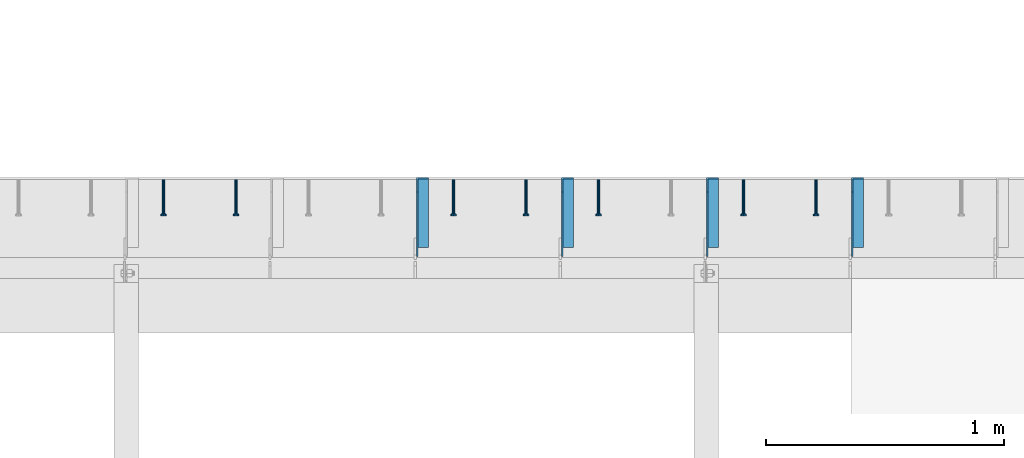
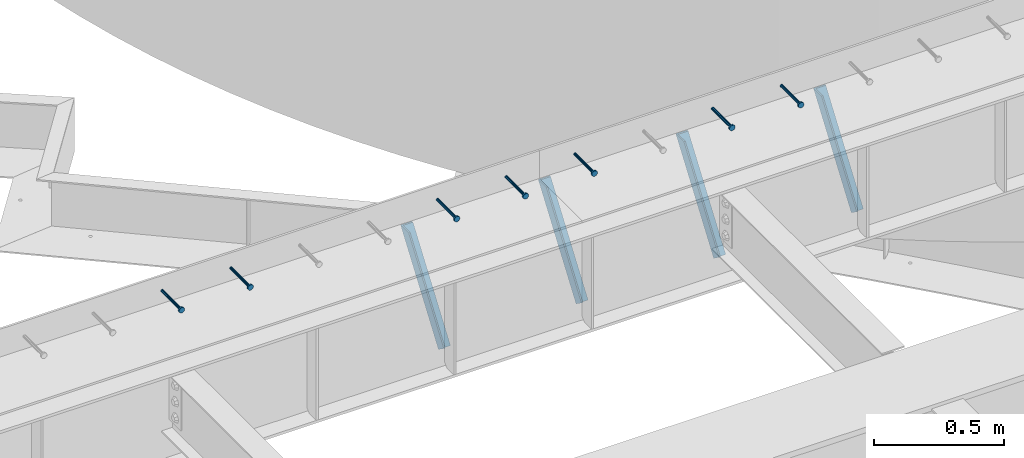
# One storey, part 1351 of 1763: 7 beams, 4 members, 8 elements without a shape of their own.
"""IFC2X3 building model written with IfcOpenShell, lengths in millimetres."""

from ifc_helpers import new_model, si_unit, frame, origin_with_axes, place, context, subcontext, project, spatial, faceted_brep, material, type_object, element, aggregate, save


model = new_model("IFC2X3")

# Units and contexts
model_context = context("Model", 3, precision=1e-05, world=origin_with_axes())
body_context = subcontext(model_context, "Body", "Model", "MODEL_VIEW")
ifc_project = project(units=[si_unit("LENGTHUNIT", "METRE", prefix="MILLI"), si_unit("AREAUNIT", "SQUARE_METRE"), si_unit("VOLUMEUNIT", "CUBIC_METRE"), si_unit("MASSUNIT", "GRAM", prefix="KILO"), si_unit("TIMEUNIT", "SECOND"), si_unit("PLANEANGLEUNIT", "RADIAN"), si_unit("SOLIDANGLEUNIT", "STERADIAN"), si_unit("THERMODYNAMICTEMPERATUREUNIT", "DEGREE_CELSIUS"), si_unit("LUMINOUSINTENSITYUNIT", "LUMEN")], contexts=[model_context])

# Site, building, storey
site_placement = place(None, origin_with_axes())
site = spatial("IfcSite", under=ifc_project, at=site_placement, CompositionType="ELEMENT")
building_placement = place(site_placement, origin_with_axes())
building = spatial("IfcBuilding", under=site, at=building_placement, Name="Undefined", CompositionType="ELEMENT")
storey_placement = place(building_placement, origin_with_axes())
storey = spatial("IfcBuildingStorey", under=building, at=storey_placement, Name="Undefined", CompositionType="ELEMENT", Elevation=0.0)

# Assembly, beam
assembly_1_placement = place(storey_placement, origin_with_axes())
assembly_1 = element("IfcElementAssembly", 1, at=assembly_1_placement, inside=storey, Name="HEADED STUD ANCHOR", AssemblyPlace="NOTDEFINED", PredefinedType="RIGID_FRAME")
ifc_material_1 = material(Name="STEEL/A108")
beam_type = type_object("IfcBeamType", PredefinedType="NOTDEFINED")
beam_1_placement = place(assembly_1_placement, frame((-51378.8747736983, 53984.5250183106, 5264.23140606069), z_axis=(0.0, 0.0, 1.0), x_axis=(0.0, -1.0, 0.0)))
beam_1 = element("IfcBeam", 2, at=beam_1_placement, type_object=beam_type, material=ifc_material_1, Name="HEADED STUD ANCHOR", context=body_context, shape_type="Brep", body=[
    faceted_brep([(0.0, -3.1800000667572, 5.5), (0.0, -5.5, 3.1800000667572), (141.732000000002, -5.5, 3.1800000667572), (141.732000000002, -3.1800000667572, 5.5), (0.0, -6.34999999999491, 1.45519152283669e-11), (141.732000000002, -6.34999990463257, 0.0), (0.0, -5.5, -3.1800000667572), (141.732000000002, -5.5, -3.1800000667572), (0.0, -3.1800000667572, -5.5), (141.732000000002, -3.1800000667572, -5.5), (0.0, 0.0, -6.34999990463257), (141.732000000002, 0.0, -6.34999990463257), (0.0, 3.1800000667572, -5.5), (141.732000000002, 3.1800000667572, -5.5), (0.0, 5.5, -3.1800000667572), (141.732000000002, 5.5, -3.1800000667572), (0.0, 6.34999999999491, -2.91038304567337e-11), (141.732000000002, 6.34999990463257, 0.0), (0.0, 5.5, 3.1800000667572), (141.732000000002, 5.5, 3.1800000667572), (0.0, 3.1800000667572, 5.5), (141.732000000002, 3.1800000667572, 5.5), (0.0, 0.0, 6.34999990463257), (141.732000000002, 0.0, 6.34999990463257), (144.780000000001, -10.9899997711182, 6.34999990463257), (144.780000000001, -6.34000015258789, 10.9899997711182), (144.780000000001, -12.6999998092651, 0.0), (144.780000000001, -10.9899997711182, -6.34999990463257), (144.780000000001, -6.34000015258789, -10.9899997711182), (144.780000000001, 0.0, -12.6899995803833), (144.780000000001, 6.34000015258789, -10.9899997711182), (144.780000000001, 10.9899997711182, -6.34999990463257), (144.780000000001, 12.6999998092651, 0.0), (144.780000000001, 10.9899997711182, 6.34999990463257), (144.780000000001, 6.34000015258789, 10.9899997711182), (144.780000000001, 0.0, 12.6899995803833), (152.400000000001, -10.9899997711182, 6.34999990463257), (152.400000000001, -6.34000015258789, 10.9899997711182), (152.400000000001, -12.6999998092651, 0.0), (152.400000000001, -10.9899997711182, -6.34999990463257), (152.400000000001, -6.34000015258789, -10.9899997711182), (152.400000000001, 0.0, -12.6899995803833), (152.400000000001, 6.34000015258789, -10.9899997711182), (152.400000000001, 10.9899997711182, -6.34999990463257), (152.400000000001, 12.6999998092651, 0.0), (152.400000000001, 10.9899997711182, 6.34999990463257), (152.400000000001, 6.34000015258789, 10.9899997711182), (152.400000000001, 0.0, 12.6899995803833)], [[[0, 1, 2, 3]], [[1, 4, 5, 2]], [[4, 6, 7, 5]], [[6, 8, 9, 7]], [[8, 10, 11, 9]], [[10, 12, 13, 11]], [[12, 14, 15, 13]], [[14, 16, 17, 15]], [[16, 18, 19, 17]], [[18, 20, 21, 19]], [[20, 22, 23, 21]], [[22, 0, 3, 23]], [[22, 20, 18, 16, 14, 12, 10, 8, 6, 4, 1, 0]], [[3, 2, 24, 25]], [[2, 5, 26, 24]], [[5, 7, 27, 26]], [[7, 9, 28, 27]], [[9, 11, 29, 28]], [[11, 13, 30, 29]], [[13, 15, 31, 30]], [[15, 17, 32, 31]], [[17, 19, 33, 32]], [[19, 21, 34, 33]], [[21, 23, 35, 34]], [[23, 3, 25, 35]], [[25, 24, 36, 37]], [[24, 26, 38, 36]], [[26, 27, 39, 38]], [[27, 28, 40, 39]], [[28, 29, 41, 40]], [[29, 30, 42, 41]], [[30, 31, 43, 42]], [[31, 32, 44, 43]], [[32, 33, 45, 44]], [[33, 34, 46, 45]], [[34, 35, 47, 46]], [[35, 25, 37, 47]], [[38, 39, 40, 41, 42, 43, 44, 45, 46, 47, 37, 36]]]),
])
aggregate(assembly_1, [beam_1])

assembly_2_placement = place(storey_placement, origin_with_axes())
assembly_2 = element("IfcElementAssembly", 3, at=assembly_2_placement, inside=storey, Name="HEADED STUD ANCHOR", AssemblyPlace="NOTDEFINED", PredefinedType="RIGID_FRAME")
beam_2_placement = place(assembly_2_placement, frame((-51683.6747736983, 53984.5250183106, 5264.23140606069), z_axis=(0.0, 0.0, 1.0), x_axis=(0.0, -1.0, 0.0)))
beam_2 = element("IfcBeam", 4, at=beam_2_placement, type_object=beam_type, material=ifc_material_1, Name="HEADED STUD ANCHOR", context=body_context, shape_type="Brep", body=[
    faceted_brep([(0.0, -3.1800000667572, 5.5), (0.0, -5.5, 3.1800000667572), (141.732000000002, -5.5, 3.1800000667572), (141.732000000002, -3.1800000667572, 5.5), (0.0, -6.34999999999491, 1.45519152283669e-11), (141.732000000002, -6.34999990463257, 0.0), (0.0, -5.5, -3.1800000667572), (141.732000000002, -5.5, -3.1800000667572), (0.0, -3.1800000667572, -5.5), (141.732000000002, -3.1800000667572, -5.5), (0.0, 0.0, -6.34999990463257), (141.732000000002, 0.0, -6.34999990463257), (0.0, 3.1800000667572, -5.5), (141.732000000002, 3.1800000667572, -5.5), (0.0, 5.5, -3.1800000667572), (141.732000000002, 5.5, -3.1800000667572), (0.0, 6.34999999999491, -2.91038304567337e-11), (141.732000000002, 6.34999990463257, 0.0), (0.0, 5.5, 3.1800000667572), (141.732000000002, 5.5, 3.1800000667572), (0.0, 3.1800000667572, 5.5), (141.732000000002, 3.1800000667572, 5.5), (0.0, 0.0, 6.34999990463257), (141.732000000002, 0.0, 6.34999990463257), (144.780000000001, -10.9899997711182, 6.34999990463257), (144.780000000001, -6.34000015258789, 10.9899997711182), (144.780000000001, -12.6999998092651, 0.0), (144.780000000001, -10.9899997711182, -6.34999990463257), (144.780000000001, -6.34000015258789, -10.9899997711182), (144.780000000001, 0.0, -12.6899995803833), (144.780000000001, 6.34000015258789, -10.9899997711182), (144.780000000001, 10.9899997711182, -6.34999990463257), (144.780000000001, 12.6999998092651, 0.0), (144.780000000001, 10.9899997711182, 6.34999990463257), (144.780000000001, 6.34000015258789, 10.9899997711182), (144.780000000001, 0.0, 12.6899995803833), (152.400000000001, -10.9899997711182, 6.34999990463257), (152.400000000001, -6.34000015258789, 10.9899997711182), (152.400000000001, -12.6999998092651, 0.0), (152.400000000001, -10.9899997711182, -6.34999990463257), (152.400000000001, -6.34000015258789, -10.9899997711182), (152.400000000001, 0.0, -12.6899995803833), (152.400000000001, 6.34000015258789, -10.9899997711182), (152.400000000001, 10.9899997711182, -6.34999990463257), (152.400000000001, 12.6999998092651, 0.0), (152.400000000001, 10.9899997711182, 6.34999990463257), (152.400000000001, 6.34000015258789, 10.9899997711182), (152.400000000001, 0.0, 12.6899995803833)], [[[0, 1, 2, 3]], [[1, 4, 5, 2]], [[4, 6, 7, 5]], [[6, 8, 9, 7]], [[8, 10, 11, 9]], [[10, 12, 13, 11]], [[12, 14, 15, 13]], [[14, 16, 17, 15]], [[16, 18, 19, 17]], [[18, 20, 21, 19]], [[20, 22, 23, 21]], [[22, 0, 3, 23]], [[22, 20, 18, 16, 14, 12, 10, 8, 6, 4, 1, 0]], [[3, 2, 24, 25]], [[2, 5, 26, 24]], [[5, 7, 27, 26]], [[7, 9, 28, 27]], [[9, 11, 29, 28]], [[11, 13, 30, 29]], [[13, 15, 31, 30]], [[15, 17, 32, 31]], [[17, 19, 33, 32]], [[19, 21, 34, 33]], [[21, 23, 35, 34]], [[23, 3, 25, 35]], [[25, 24, 36, 37]], [[24, 26, 38, 36]], [[26, 27, 39, 38]], [[27, 28, 40, 39]], [[28, 29, 41, 40]], [[29, 30, 42, 41]], [[30, 31, 43, 42]], [[31, 32, 44, 43]], [[32, 33, 45, 44]], [[33, 34, 46, 45]], [[34, 35, 47, 46]], [[35, 25, 37, 47]], [[38, 39, 40, 41, 42, 43, 44, 45, 46, 47, 37, 36]]]),
])
aggregate(assembly_2, [beam_2])

assembly_3_placement = place(storey_placement, origin_with_axes())
assembly_3 = element("IfcElementAssembly", 5, at=assembly_3_placement, inside=storey, Name="HEADED STUD ANCHOR", AssemblyPlace="NOTDEFINED", PredefinedType="RIGID_FRAME")
beam_3_placement = place(assembly_3_placement, frame((-52293.2747736983, 53984.5250183106, 5264.23140606069), z_axis=(0.0, 0.0, 1.0), x_axis=(0.0, -1.0, 0.0)))
beam_3 = element("IfcBeam", 6, at=beam_3_placement, type_object=beam_type, material=ifc_material_1, Name="HEADED STUD ANCHOR", context=body_context, shape_type="Brep", body=[
    faceted_brep([(0.0, -3.1800000667572, 5.5), (0.0, -5.5, 3.1800000667572), (141.732000000002, -5.5, 3.1800000667572), (141.732000000002, -3.1800000667572, 5.5), (0.0, -6.34999999999491, 1.45519152283669e-11), (141.732000000002, -6.34999990463257, 0.0), (0.0, -5.5, -3.1800000667572), (141.732000000002, -5.5, -3.1800000667572), (0.0, -3.1800000667572, -5.5), (141.732000000002, -3.1800000667572, -5.5), (0.0, 0.0, -6.34999990463257), (141.732000000002, 0.0, -6.34999990463257), (0.0, 3.1800000667572, -5.5), (141.732000000002, 3.1800000667572, -5.5), (0.0, 5.5, -3.1800000667572), (141.732000000002, 5.5, -3.1800000667572), (0.0, 6.34999999999491, -2.91038304567337e-11), (141.732000000002, 6.34999990463257, 0.0), (0.0, 5.5, 3.1800000667572), (141.732000000002, 5.5, 3.1800000667572), (0.0, 3.1800000667572, 5.5), (141.732000000002, 3.1800000667572, 5.5), (0.0, 0.0, 6.34999990463257), (141.732000000002, 0.0, 6.34999990463257), (144.780000000001, -10.9899997711182, 6.34999990463257), (144.780000000001, -6.34000015258789, 10.9899997711182), (144.780000000001, -12.6999998092651, 0.0), (144.780000000001, -10.9899997711182, -6.34999990463257), (144.780000000001, -6.34000015258789, -10.9899997711182), (144.780000000001, 0.0, -12.6899995803833), (144.780000000001, 6.34000015258789, -10.9899997711182), (144.780000000001, 10.9899997711182, -6.34999990463257), (144.780000000001, 12.6999998092651, 0.0), (144.780000000001, 10.9899997711182, 6.34999990463257), (144.780000000001, 6.34000015258789, 10.9899997711182), (144.780000000001, 0.0, 12.6899995803833), (152.400000000001, -10.9899997711182, 6.34999990463257), (152.400000000001, -6.34000015258789, 10.9899997711182), (152.400000000001, -12.6999998092651, 0.0), (152.400000000001, -10.9899997711182, -6.34999990463257), (152.400000000001, -6.34000015258789, -10.9899997711182), (152.400000000001, 0.0, -12.6899995803833), (152.400000000001, 6.34000015258789, -10.9899997711182), (152.400000000001, 10.9899997711182, -6.34999990463257), (152.400000000001, 12.6999998092651, 0.0), (152.400000000001, 10.9899997711182, 6.34999990463257), (152.400000000001, 6.34000015258789, 10.9899997711182), (152.400000000001, 0.0, 12.6899995803833)], [[[0, 1, 2, 3]], [[1, 4, 5, 2]], [[4, 6, 7, 5]], [[6, 8, 9, 7]], [[8, 10, 11, 9]], [[10, 12, 13, 11]], [[12, 14, 15, 13]], [[14, 16, 17, 15]], [[16, 18, 19, 17]], [[18, 20, 21, 19]], [[20, 22, 23, 21]], [[22, 0, 3, 23]], [[22, 20, 18, 16, 14, 12, 10, 8, 6, 4, 1, 0]], [[3, 2, 24, 25]], [[2, 5, 26, 24]], [[5, 7, 27, 26]], [[7, 9, 28, 27]], [[9, 11, 29, 28]], [[11, 13, 30, 29]], [[13, 15, 31, 30]], [[15, 17, 32, 31]], [[17, 19, 33, 32]], [[19, 21, 34, 33]], [[21, 23, 35, 34]], [[23, 3, 25, 35]], [[25, 24, 36, 37]], [[24, 26, 38, 36]], [[26, 27, 39, 38]], [[27, 28, 40, 39]], [[28, 29, 41, 40]], [[29, 30, 42, 41]], [[30, 31, 43, 42]], [[31, 32, 44, 43]], [[32, 33, 45, 44]], [[33, 34, 46, 45]], [[34, 35, 47, 46]], [[35, 25, 37, 47]], [[38, 39, 40, 41, 42, 43, 44, 45, 46, 47, 37, 36]]]),
])
aggregate(assembly_3, [beam_3])

assembly_4_placement = place(storey_placement, origin_with_axes())
assembly_4 = element("IfcElementAssembly", 7, at=assembly_4_placement, inside=storey, Name="HEADED STUD ANCHOR", AssemblyPlace="NOTDEFINED", PredefinedType="RIGID_FRAME")
beam_4_placement = place(assembly_4_placement, frame((-52598.0747736983, 53984.5250183106, 5264.23140606069), z_axis=(0.0, 0.0, 1.0), x_axis=(0.0, -1.0, 0.0)))
beam_4 = element("IfcBeam", 8, at=beam_4_placement, type_object=beam_type, material=ifc_material_1, Name="HEADED STUD ANCHOR", context=body_context, shape_type="Brep", body=[
    faceted_brep([(0.0, -3.1800000667572, 5.5), (0.0, -5.5, 3.1800000667572), (141.732000000002, -5.5, 3.1800000667572), (141.732000000002, -3.1800000667572, 5.5), (0.0, -6.34999999999491, 1.45519152283669e-11), (141.732000000002, -6.34999990463257, 0.0), (0.0, -5.5, -3.1800000667572), (141.732000000002, -5.5, -3.1800000667572), (0.0, -3.1800000667572, -5.5), (141.732000000002, -3.1800000667572, -5.5), (0.0, 0.0, -6.34999990463257), (141.732000000002, 0.0, -6.34999990463257), (0.0, 3.1800000667572, -5.5), (141.732000000002, 3.1800000667572, -5.5), (0.0, 5.5, -3.1800000667572), (141.732000000002, 5.5, -3.1800000667572), (0.0, 6.34999999999491, -2.91038304567337e-11), (141.732000000002, 6.34999990463257, 0.0), (0.0, 5.5, 3.1800000667572), (141.732000000002, 5.5, 3.1800000667572), (0.0, 3.1800000667572, 5.5), (141.732000000002, 3.1800000667572, 5.5), (0.0, 0.0, 6.34999990463257), (141.732000000002, 0.0, 6.34999990463257), (144.780000000001, -10.9899997711182, 6.34999990463257), (144.780000000001, -6.34000015258789, 10.9899997711182), (144.780000000001, -12.6999998092651, 0.0), (144.780000000001, -10.9899997711182, -6.34999990463257), (144.780000000001, -6.34000015258789, -10.9899997711182), (144.780000000001, 0.0, -12.6899995803833), (144.780000000001, 6.34000015258789, -10.9899997711182), (144.780000000001, 10.9899997711182, -6.34999990463257), (144.780000000001, 12.6999998092651, 0.0), (144.780000000001, 10.9899997711182, 6.34999990463257), (144.780000000001, 6.34000015258789, 10.9899997711182), (144.780000000001, 0.0, 12.6899995803833), (152.400000000001, -10.9899997711182, 6.34999990463257), (152.400000000001, -6.34000015258789, 10.9899997711182), (152.400000000001, -12.6999998092651, 0.0), (152.400000000001, -10.9899997711182, -6.34999990463257), (152.400000000001, -6.34000015258789, -10.9899997711182), (152.400000000001, 0.0, -12.6899995803833), (152.400000000001, 6.34000015258789, -10.9899997711182), (152.400000000001, 10.9899997711182, -6.34999990463257), (152.400000000001, 12.6999998092651, 0.0), (152.400000000001, 10.9899997711182, 6.34999990463257), (152.400000000001, 6.34000015258789, 10.9899997711182), (152.400000000001, 0.0, 12.6899995803833)], [[[0, 1, 2, 3]], [[1, 4, 5, 2]], [[4, 6, 7, 5]], [[6, 8, 9, 7]], [[8, 10, 11, 9]], [[10, 12, 13, 11]], [[12, 14, 15, 13]], [[14, 16, 17, 15]], [[16, 18, 19, 17]], [[18, 20, 21, 19]], [[20, 22, 23, 21]], [[22, 0, 3, 23]], [[22, 20, 18, 16, 14, 12, 10, 8, 6, 4, 1, 0]], [[3, 2, 24, 25]], [[2, 5, 26, 24]], [[5, 7, 27, 26]], [[7, 9, 28, 27]], [[9, 11, 29, 28]], [[11, 13, 30, 29]], [[13, 15, 31, 30]], [[15, 17, 32, 31]], [[17, 19, 33, 32]], [[19, 21, 34, 33]], [[21, 23, 35, 34]], [[23, 3, 25, 35]], [[25, 24, 36, 37]], [[24, 26, 38, 36]], [[26, 27, 39, 38]], [[27, 28, 40, 39]], [[28, 29, 41, 40]], [[29, 30, 42, 41]], [[30, 31, 43, 42]], [[31, 32, 44, 43]], [[32, 33, 45, 44]], [[33, 34, 46, 45]], [[34, 35, 47, 46]], [[35, 25, 37, 47]], [[38, 39, 40, 41, 42, 43, 44, 45, 46, 47, 37, 36]]]),
])
aggregate(assembly_4, [beam_4])

assembly_5_placement = place(storey_placement, origin_with_axes())
assembly_5 = element("IfcElementAssembly", 9, at=assembly_5_placement, inside=storey, Name="HEADED STUD ANCHOR", AssemblyPlace="NOTDEFINED", PredefinedType="RIGID_FRAME")
beam_5_placement = place(assembly_5_placement, frame((-52902.8747736983, 53984.5250183106, 5264.23140606069), z_axis=(0.0, 0.0, 1.0), x_axis=(0.0, -1.0, 0.0)))
beam_5 = element("IfcBeam", 10, at=beam_5_placement, type_object=beam_type, material=ifc_material_1, Name="HEADED STUD ANCHOR", context=body_context, shape_type="Brep", body=[
    faceted_brep([(0.0, -3.1800000667572, 5.5), (0.0, -5.5, 3.1800000667572), (141.732000000002, -5.5, 3.1800000667572), (141.732000000002, -3.1800000667572, 5.5), (0.0, -6.34999999999491, 1.45519152283669e-11), (141.732000000002, -6.34999990463257, 0.0), (0.0, -5.5, -3.1800000667572), (141.732000000002, -5.5, -3.1800000667572), (0.0, -3.1800000667572, -5.5), (141.732000000002, -3.1800000667572, -5.5), (0.0, 0.0, -6.34999990463257), (141.732000000002, 0.0, -6.34999990463257), (0.0, 3.1800000667572, -5.5), (141.732000000002, 3.1800000667572, -5.5), (0.0, 5.5, -3.1800000667572), (141.732000000002, 5.5, -3.1800000667572), (0.0, 6.34999999999491, -2.91038304567337e-11), (141.732000000002, 6.34999990463257, 0.0), (0.0, 5.5, 3.1800000667572), (141.732000000002, 5.5, 3.1800000667572), (0.0, 3.1800000667572, 5.5), (141.732000000002, 3.1800000667572, 5.5), (0.0, 0.0, 6.34999990463257), (141.732000000002, 0.0, 6.34999990463257), (144.780000000001, -10.9899997711182, 6.34999990463257), (144.780000000001, -6.34000015258789, 10.9899997711182), (144.780000000001, -12.6999998092651, 0.0), (144.780000000001, -10.9899997711182, -6.34999990463257), (144.780000000001, -6.34000015258789, -10.9899997711182), (144.780000000001, 0.0, -12.6899995803833), (144.780000000001, 6.34000015258789, -10.9899997711182), (144.780000000001, 10.9899997711182, -6.34999990463257), (144.780000000001, 12.6999998092651, 0.0), (144.780000000001, 10.9899997711182, 6.34999990463257), (144.780000000001, 6.34000015258789, 10.9899997711182), (144.780000000001, 0.0, 12.6899995803833), (152.400000000001, -10.9899997711182, 6.34999990463257), (152.400000000001, -6.34000015258789, 10.9899997711182), (152.400000000001, -12.6999998092651, 0.0), (152.400000000001, -10.9899997711182, -6.34999990463257), (152.400000000001, -6.34000015258789, -10.9899997711182), (152.400000000001, 0.0, -12.6899995803833), (152.400000000001, 6.34000015258789, -10.9899997711182), (152.400000000001, 10.9899997711182, -6.34999990463257), (152.400000000001, 12.6999998092651, 0.0), (152.400000000001, 10.9899997711182, 6.34999990463257), (152.400000000001, 6.34000015258789, 10.9899997711182), (152.400000000001, 0.0, 12.6899995803833)], [[[0, 1, 2, 3]], [[1, 4, 5, 2]], [[4, 6, 7, 5]], [[6, 8, 9, 7]], [[8, 10, 11, 9]], [[10, 12, 13, 11]], [[12, 14, 15, 13]], [[14, 16, 17, 15]], [[16, 18, 19, 17]], [[18, 20, 21, 19]], [[20, 22, 23, 21]], [[22, 0, 3, 23]], [[22, 20, 18, 16, 14, 12, 10, 8, 6, 4, 1, 0]], [[3, 2, 24, 25]], [[2, 5, 26, 24]], [[5, 7, 27, 26]], [[7, 9, 28, 27]], [[9, 11, 29, 28]], [[11, 13, 30, 29]], [[13, 15, 31, 30]], [[15, 17, 32, 31]], [[17, 19, 33, 32]], [[19, 21, 34, 33]], [[21, 23, 35, 34]], [[23, 3, 25, 35]], [[25, 24, 36, 37]], [[24, 26, 38, 36]], [[26, 27, 39, 38]], [[27, 28, 40, 39]], [[28, 29, 41, 40]], [[29, 30, 42, 41]], [[30, 31, 43, 42]], [[31, 32, 44, 43]], [[32, 33, 45, 44]], [[33, 34, 46, 45]], [[34, 35, 47, 46]], [[35, 25, 37, 47]], [[38, 39, 40, 41, 42, 43, 44, 45, 46, 47, 37, 36]]]),
])
aggregate(assembly_5, [beam_5])

assembly_6_placement = place(storey_placement, origin_with_axes())
assembly_6 = element("IfcElementAssembly", 11, at=assembly_6_placement, inside=storey, Name="HEADED STUD ANCHOR", AssemblyPlace="NOTDEFINED", PredefinedType="RIGID_FRAME")
beam_6_placement = place(assembly_6_placement, frame((-53817.2747736983, 53984.5250183106, 5264.23140606069), z_axis=(0.0, 0.0, 1.0), x_axis=(0.0, -1.0, 0.0)))
beam_6 = element("IfcBeam", 12, at=beam_6_placement, type_object=beam_type, material=ifc_material_1, Name="HEADED STUD ANCHOR", context=body_context, shape_type="Brep", body=[
    faceted_brep([(0.0, -3.1800000667572, 5.5), (0.0, -5.5, 3.1800000667572), (141.732000000002, -5.5, 3.1800000667572), (141.732000000002, -3.1800000667572, 5.5), (0.0, -6.34999999999491, 1.45519152283669e-11), (141.732000000002, -6.34999990463257, 0.0), (0.0, -5.5, -3.1800000667572), (141.732000000002, -5.5, -3.1800000667572), (0.0, -3.1800000667572, -5.5), (141.732000000002, -3.1800000667572, -5.5), (0.0, 0.0, -6.34999990463257), (141.732000000002, 0.0, -6.34999990463257), (0.0, 3.1800000667572, -5.5), (141.732000000002, 3.1800000667572, -5.5), (0.0, 5.5, -3.1800000667572), (141.732000000002, 5.5, -3.1800000667572), (0.0, 6.34999999999491, -2.91038304567337e-11), (141.732000000002, 6.34999990463257, 0.0), (0.0, 5.5, 3.1800000667572), (141.732000000002, 5.5, 3.1800000667572), (0.0, 3.1800000667572, 5.5), (141.732000000002, 3.1800000667572, 5.5), (0.0, 0.0, 6.34999990463257), (141.732000000002, 0.0, 6.34999990463257), (144.780000000001, -10.9899997711182, 6.34999990463257), (144.780000000001, -6.34000015258789, 10.9899997711182), (144.780000000001, -12.6999998092651, 0.0), (144.780000000001, -10.9899997711182, -6.34999990463257), (144.780000000001, -6.34000015258789, -10.9899997711182), (144.780000000001, 0.0, -12.6899995803833), (144.780000000001, 6.34000015258789, -10.9899997711182), (144.780000000001, 10.9899997711182, -6.34999990463257), (144.780000000001, 12.6999998092651, 0.0), (144.780000000001, 10.9899997711182, 6.34999990463257), (144.780000000001, 6.34000015258789, 10.9899997711182), (144.780000000001, 0.0, 12.6899995803833), (152.400000000001, -10.9899997711182, 6.34999990463257), (152.400000000001, -6.34000015258789, 10.9899997711182), (152.400000000001, -12.6999998092651, 0.0), (152.400000000001, -10.9899997711182, -6.34999990463257), (152.400000000001, -6.34000015258789, -10.9899997711182), (152.400000000001, 0.0, -12.6899995803833), (152.400000000001, 6.34000015258789, -10.9899997711182), (152.400000000001, 10.9899997711182, -6.34999990463257), (152.400000000001, 12.6999998092651, 0.0), (152.400000000001, 10.9899997711182, 6.34999990463257), (152.400000000001, 6.34000015258789, 10.9899997711182), (152.400000000001, 0.0, 12.6899995803833)], [[[0, 1, 2, 3]], [[1, 4, 5, 2]], [[4, 6, 7, 5]], [[6, 8, 9, 7]], [[8, 10, 11, 9]], [[10, 12, 13, 11]], [[12, 14, 15, 13]], [[14, 16, 17, 15]], [[16, 18, 19, 17]], [[18, 20, 21, 19]], [[20, 22, 23, 21]], [[22, 0, 3, 23]], [[22, 20, 18, 16, 14, 12, 10, 8, 6, 4, 1, 0]], [[3, 2, 24, 25]], [[2, 5, 26, 24]], [[5, 7, 27, 26]], [[7, 9, 28, 27]], [[9, 11, 29, 28]], [[11, 13, 30, 29]], [[13, 15, 31, 30]], [[15, 17, 32, 31]], [[17, 19, 33, 32]], [[19, 21, 34, 33]], [[21, 23, 35, 34]], [[23, 3, 25, 35]], [[25, 24, 36, 37]], [[24, 26, 38, 36]], [[26, 27, 39, 38]], [[27, 28, 40, 39]], [[28, 29, 41, 40]], [[29, 30, 42, 41]], [[30, 31, 43, 42]], [[31, 32, 44, 43]], [[32, 33, 45, 44]], [[33, 34, 46, 45]], [[34, 35, 47, 46]], [[35, 25, 37, 47]], [[38, 39, 40, 41, 42, 43, 44, 45, 46, 47, 37, 36]]]),
])
aggregate(assembly_6, [beam_6])

assembly_7_placement = place(storey_placement, origin_with_axes())
assembly_7 = element("IfcElementAssembly", 13, at=assembly_7_placement, inside=storey, Name="HEADED STUD ANCHOR", AssemblyPlace="NOTDEFINED", PredefinedType="RIGID_FRAME")
beam_7_placement = place(assembly_7_placement, frame((-54122.0747736983, 53984.5250183106, 5264.23140606069), z_axis=(0.0, 0.0, 1.0), x_axis=(0.0, -1.0, 0.0)))
beam_7 = element("IfcBeam", 14, at=beam_7_placement, type_object=beam_type, material=ifc_material_1, Name="HEADED STUD ANCHOR", context=body_context, shape_type="Brep", body=[
    faceted_brep([(0.0, -3.1800000667572, 5.5), (0.0, -5.5, 3.1800000667572), (141.732000000002, -5.5, 3.1800000667572), (141.732000000002, -3.1800000667572, 5.5), (0.0, -6.34999999999491, 1.45519152283669e-11), (141.732000000002, -6.34999990463257, 0.0), (0.0, -5.5, -3.1800000667572), (141.732000000002, -5.5, -3.1800000667572), (0.0, -3.1800000667572, -5.5), (141.732000000002, -3.1800000667572, -5.5), (0.0, 0.0, -6.34999990463257), (141.732000000002, 0.0, -6.34999990463257), (0.0, 3.1800000667572, -5.5), (141.732000000002, 3.1800000667572, -5.5), (0.0, 5.5, -3.1800000667572), (141.732000000002, 5.5, -3.1800000667572), (0.0, 6.34999999999491, -2.91038304567337e-11), (141.732000000002, 6.34999990463257, 0.0), (0.0, 5.5, 3.1800000667572), (141.732000000002, 5.5, 3.1800000667572), (0.0, 3.1800000667572, 5.5), (141.732000000002, 3.1800000667572, 5.5), (0.0, 0.0, 6.34999990463257), (141.732000000002, 0.0, 6.34999990463257), (144.780000000001, -10.9899997711182, 6.34999990463257), (144.780000000001, -6.34000015258789, 10.9899997711182), (144.780000000001, -12.6999998092651, 0.0), (144.780000000001, -10.9899997711182, -6.34999990463257), (144.780000000001, -6.34000015258789, -10.9899997711182), (144.780000000001, 0.0, -12.6899995803833), (144.780000000001, 6.34000015258789, -10.9899997711182), (144.780000000001, 10.9899997711182, -6.34999990463257), (144.780000000001, 12.6999998092651, 0.0), (144.780000000001, 10.9899997711182, 6.34999990463257), (144.780000000001, 6.34000015258789, 10.9899997711182), (144.780000000001, 0.0, 12.6899995803833), (152.400000000001, -10.9899997711182, 6.34999990463257), (152.400000000001, -6.34000015258789, 10.9899997711182), (152.400000000001, -12.6999998092651, 0.0), (152.400000000001, -10.9899997711182, -6.34999990463257), (152.400000000001, -6.34000015258789, -10.9899997711182), (152.400000000001, 0.0, -12.6899995803833), (152.400000000001, 6.34000015258789, -10.9899997711182), (152.400000000001, 10.9899997711182, -6.34999990463257), (152.400000000001, 12.6999998092651, 0.0), (152.400000000001, 10.9899997711182, 6.34999990463257), (152.400000000001, 6.34000015258789, 10.9899997711182), (152.400000000001, 0.0, 12.6899995803833)], [[[0, 1, 2, 3]], [[1, 4, 5, 2]], [[4, 6, 7, 5]], [[6, 8, 9, 7]], [[8, 10, 11, 9]], [[10, 12, 13, 11]], [[12, 14, 15, 13]], [[14, 16, 17, 15]], [[16, 18, 19, 17]], [[18, 20, 21, 19]], [[20, 22, 23, 21]], [[22, 0, 3, 23]], [[22, 20, 18, 16, 14, 12, 10, 8, 6, 4, 1, 0]], [[3, 2, 24, 25]], [[2, 5, 26, 24]], [[5, 7, 27, 26]], [[7, 9, 28, 27]], [[9, 11, 29, 28]], [[11, 13, 30, 29]], [[13, 15, 31, 30]], [[15, 17, 32, 31]], [[17, 19, 33, 32]], [[19, 21, 34, 33]], [[21, 23, 35, 34]], [[23, 3, 25, 35]], [[25, 24, 36, 37]], [[24, 26, 38, 36]], [[26, 27, 39, 38]], [[27, 28, 40, 39]], [[28, 29, 41, 40]], [[29, 30, 42, 41]], [[30, 31, 43, 42]], [[31, 32, 44, 43]], [[32, 33, 45, 44]], [[33, 34, 46, 45]], [[34, 35, 47, 46]], [[35, 25, 37, 47]], [[38, 39, 40, 41, 42, 43, 44, 45, 46, 47, 37, 36]]]),
])
aggregate(assembly_7, [beam_7])

# Assembly, members
assembly_8_placement = place(storey_placement, origin_with_axes())
assembly_8 = element("IfcElementAssembly", 15, at=assembly_8_placement, inside=storey, Name="BEAM", AssemblyPlace="NOTDEFINED", PredefinedType="RIGID_FRAME")
ifc_material_2 = material(Name="STEEL/A36")
member_type = type_object("IfcMemberType", Name="L2X2X1/4", PredefinedType="NOTDEFINED")
member_1_placement = place(assembly_8_placement, frame((-51815.4372736983, 53682.7083833992, 4801.551610525), z_axis=(0.0, -0.814117947745209, 0.580699549818259), x_axis=(0.0, 0.58069954981826, 0.814117947745209)))
member_1 = element("IfcMember", 16, at=member_1_placement, type_object=member_type, material=ifc_material_2, Name="ANGLE", ObjectType="L2X2X1/4", context=body_context, shape_type="Brep", body=[
    faceted_brep([(-1.45519152283669e-11, 25.4000000000015, -25.3999999999869), (1.45519152283669e-11, 25.4000000000015, 25.3999999999796), (464.304493432646, 25.4000000000015, 25.3999999991429), (500.539460322936, 25.4000000000015, -25.4000000009546), (1.45519152283669e-11, 19.0499999999993, 25.3999999999796), (464.304493432646, 19.0500000000029, 25.3999999991429), (-7.27595761418343e-12, 19.0499999999993, -19.0499999999956), (496.010089461648, 19.0500000000029, -19.0500000009415), (-7.27595761418343e-12, -25.4000000000015, -19.0499999999956), (496.010089461648, -25.4000000000015, -19.0500000009415), (-1.45519152283669e-11, -25.4000000000015, -25.3999999999869), (500.539460322936, -25.4000000000015, -25.4000000009546)], [[[0, 1, 2, 3]], [[1, 4, 5, 2]], [[4, 6, 7, 5]], [[6, 8, 9, 7]], [[8, 10, 11, 9]], [[10, 0, 3, 11]], [[5, 7, 9, 11, 3, 2]], [[10, 8, 6, 4, 1, 0]]]),
])
member_2_placement = place(assembly_8_placement, frame((-53034.6372736984, 53682.7083833992, 4801.551610525), z_axis=(0.0, -0.814117947745209, 0.580699549818259), x_axis=(0.0, 0.58069954981826, 0.814117947745209)))
member_2 = element("IfcMember", 17, at=member_2_placement, type_object=member_type, material=ifc_material_2, Name="ANGLE", ObjectType="L2X2X1/4", context=body_context, shape_type="Brep", body=[
    faceted_brep([(-1.45519152283669e-11, 25.4000000000015, -25.3999999999869), (1.45519152283669e-11, 25.4000000000015, 25.3999999999796), (464.304493432646, 25.4000000000015, 25.3999999991429), (500.539460322936, 25.4000000000015, -25.4000000009546), (1.45519152283669e-11, 19.0499999999993, 25.3999999999796), (464.304493432646, 19.0500000000029, 25.3999999991429), (-7.27595761418343e-12, 19.0499999999993, -19.0499999999956), (496.010089461648, 19.0500000000029, -19.0500000009415), (-7.27595761418343e-12, -25.4000000000015, -19.0499999999956), (496.010089461648, -25.4000000000015, -19.0500000009415), (-1.45519152283669e-11, -25.4000000000015, -25.3999999999869), (500.539460322936, -25.4000000000015, -25.4000000009546)], [[[0, 1, 2, 3]], [[1, 4, 5, 2]], [[4, 6, 7, 5]], [[6, 8, 9, 7]], [[8, 10, 11, 9]], [[10, 0, 3, 11]], [[5, 7, 9, 11, 3, 2]], [[10, 8, 6, 4, 1, 0]]]),
])
member_3_placement = place(assembly_8_placement, frame((-51205.8372736984, 53682.7083833992, 4801.551610525), z_axis=(0.0, -0.814117947745209, 0.580699549818259), x_axis=(0.0, 0.58069954981826, 0.814117947745209)))
member_3 = element("IfcMember", 18, at=member_3_placement, type_object=member_type, material=ifc_material_2, Name="ANGLE", ObjectType="L2X2X1/4", context=body_context, shape_type="Brep", body=[
    faceted_brep([(-1.45519152283669e-11, 25.4000000000015, -25.3999999999869), (1.45519152283669e-11, 25.4000000000015, 25.3999999999796), (464.304493432646, 25.4000000000015, 25.3999999991429), (500.539460322936, 25.4000000000015, -25.4000000009546), (1.45519152283669e-11, 19.0499999999993, 25.3999999999796), (464.304493432646, 19.0500000000029, 25.3999999991429), (-7.27595761418343e-12, 19.0499999999993, -19.0499999999956), (496.010089461648, 19.0500000000029, -19.0500000009415), (-7.27595761418343e-12, -25.4000000000015, -19.0499999999956), (496.010089461648, -25.4000000000015, -19.0500000009415), (-1.45519152283669e-11, -25.4000000000015, -25.3999999999869), (500.539460322936, -25.4000000000015, -25.4000000009546)], [[[0, 1, 2, 3]], [[1, 4, 5, 2]], [[4, 6, 7, 5]], [[6, 8, 9, 7]], [[8, 10, 11, 9]], [[10, 0, 3, 11]], [[5, 7, 9, 11, 3, 2]], [[10, 8, 6, 4, 1, 0]]]),
])
member_4_placement = place(assembly_8_placement, frame((-52425.0372736983, 53682.7083833992, 4801.551610525), z_axis=(0.0, -0.814117947745209, 0.580699549818259), x_axis=(0.0, 0.58069954981826, 0.814117947745209)))
member_4 = element("IfcMember", 19, at=member_4_placement, type_object=member_type, material=ifc_material_2, Name="ANGLE", ObjectType="L2X2X1/4", context=body_context, shape_type="Brep", body=[
    faceted_brep([(-1.45519152283669e-11, 25.4000000000015, -25.3999999999869), (1.45519152283669e-11, 25.4000000000015, 25.3999999999796), (464.304493432646, 25.4000000000015, 25.3999999991429), (500.539460322936, 25.4000000000015, -25.4000000009546), (1.45519152283669e-11, 19.0499999999993, 25.3999999999796), (464.304493432646, 19.0500000000029, 25.3999999991429), (-7.27595761418343e-12, 19.0499999999993, -19.0499999999956), (496.010089461648, 19.0500000000029, -19.0500000009415), (-7.27595761418343e-12, -25.4000000000015, -19.0499999999956), (496.010089461648, -25.4000000000015, -19.0500000009415), (-1.45519152283669e-11, -25.4000000000015, -25.3999999999869), (500.539460322936, -25.4000000000015, -25.4000000009546)], [[[0, 1, 2, 3]], [[1, 4, 5, 2]], [[4, 6, 7, 5]], [[6, 8, 9, 7]], [[8, 10, 11, 9]], [[10, 0, 3, 11]], [[5, 7, 9, 11, 3, 2]], [[10, 8, 6, 4, 1, 0]]]),
])
aggregate(assembly_8, [member_1, member_2, member_3, member_4])

save(model, "model.ifc")
